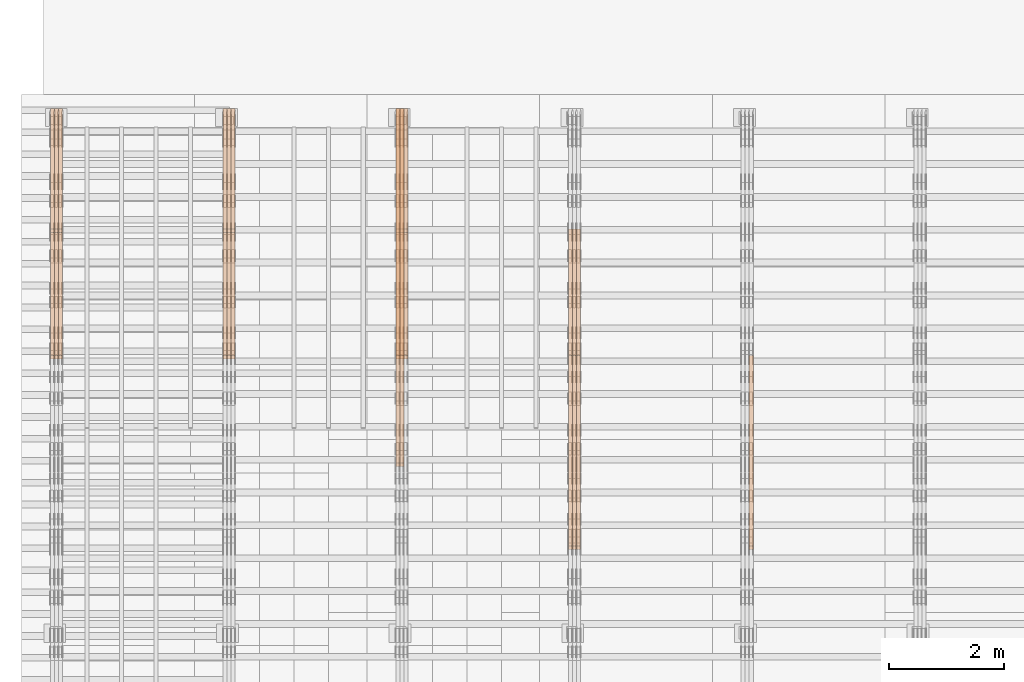
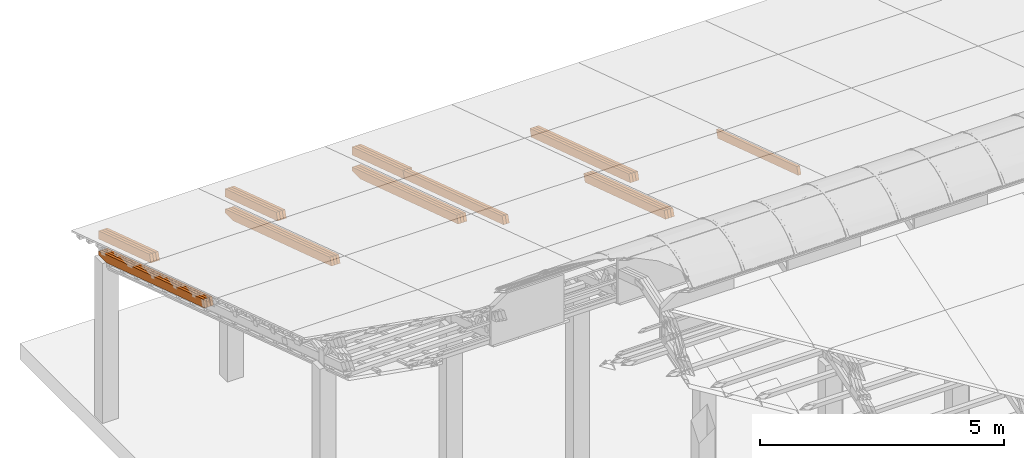
# One storey, part 20 of 385: 27 proxies.
"""IFC2X3 building model written with IfcOpenShell, lengths in millimetres."""

from ifc_helpers import new_model, entity, si_unit, converted_unit, derived_unit, direction, frame, origin, place, context, subcontext, project, spatial, polyline, outline, extrude, source, transform, mapped, material, type_object, type_shapes, element, save


model = new_model("IFC2X3")

# Units and contexts
model_context = context("Model", 3, precision=0.01, world=origin(), true_north=direction((6.12303176911189e-17, 1.0)))
body_context = subcontext(model_context, "Body", "Model", "MODEL_VIEW")
ifc_project = project(units=[si_unit("LENGTHUNIT", "METRE", prefix="MILLI"), si_unit("AREAUNIT", "SQUARE_METRE"), si_unit("VOLUMEUNIT", "CUBIC_METRE"), converted_unit("PLANEANGLEUNIT", "DEGREE", entity("IfcRatioMeasure", 0.0174532925199433), si_unit("PLANEANGLEUNIT", "RADIAN"), dimensions=[0, 0, 0, 0, 0, 0, 0]), si_unit("MASSUNIT", "GRAM", prefix="KILO"), derived_unit("MASSDENSITYUNIT", [(si_unit("MASSUNIT", "GRAM", prefix="KILO"), 1), (si_unit("LENGTHUNIT", "METRE"), -3)]), si_unit("TIMEUNIT", "SECOND"), si_unit("FREQUENCYUNIT", "HERTZ"), si_unit("THERMODYNAMICTEMPERATUREUNIT", "DEGREE_CELSIUS"), derived_unit("THERMALTRANSMITTANCEUNIT", [(si_unit("MASSUNIT", "GRAM", prefix="KILO"), 1), (si_unit("THERMODYNAMICTEMPERATUREUNIT", "KELVIN"), -1), (si_unit("TIMEUNIT", "SECOND"), -3)]), derived_unit("VOLUMETRICFLOWRATEUNIT", [(si_unit("LENGTHUNIT", "METRE"), 3), (si_unit("TIMEUNIT", "SECOND"), -1)]), si_unit("ELECTRICCURRENTUNIT", "AMPERE"), si_unit("ELECTRICVOLTAGEUNIT", "VOLT"), si_unit("POWERUNIT", "WATT"), si_unit("FORCEUNIT", "NEWTON", prefix="KILO"), si_unit("ILLUMINANCEUNIT", "LUX"), si_unit("LUMINOUSFLUXUNIT", "LUMEN"), si_unit("LUMINOUSINTENSITYUNIT", "CANDELA"), derived_unit("USERDEFINED", [(si_unit("MASSUNIT", "GRAM", prefix="KILO"), -1), (si_unit("LENGTHUNIT", "METRE"), -2), (si_unit("TIMEUNIT", "SECOND"), 3), (si_unit("LUMINOUSFLUXUNIT", "LUMEN"), 1)]), derived_unit("LINEARVELOCITYUNIT", [(si_unit("LENGTHUNIT", "METRE"), 1), (si_unit("TIMEUNIT", "SECOND"), -1)]), si_unit("PRESSUREUNIT", "PASCAL"), derived_unit("USERDEFINED", [(si_unit("LENGTHUNIT", "METRE"), -2), (si_unit("MASSUNIT", "GRAM", prefix="KILO"), 1), (si_unit("TIMEUNIT", "SECOND"), -2)])], contexts=[model_context])

# Site, building, storey
site_placement = place(None, origin())
site = spatial("IfcSite", under=ifc_project, at=site_placement, CompositionType="ELEMENT")
building_placement = place(site_placement, origin())
building = spatial("IfcBuilding", under=site, at=building_placement, CompositionType="ELEMENT")
storey_placement = place(building_placement, origin())
storey = spatial("IfcBuildingStorey", under=building, at=storey_placement, Name="Default", CompositionType="ELEMENT", Elevation=0.0)

# Proxies
ifc_material_1 = material(Name="IfcSurfaceStyle #144522")
building_element_proxy_type_1 = type_object("IfcBuildingElementProxyType", Name="T1-B2 144520", PredefinedType="NOTDEFINED", material=ifc_material_1)
shared_shape_1 = source(origin(), body_context, "Body", "SweptSolid", [
    extrude(outline(polyline([(-1738.61933402934, -97.4999466901035), (1738.6190788485, -97.4999466901035), (1738.6191018378, 97.4999466901035), (-1738.61884665697, 97.4999466901035), (-1738.61933402934, -97.4999466901035)])), frame((1738.6191018378, 97.4999528847471, 0.0), z_axis=(0.0, 0.0, 1.0), x_axis=(-1.0, 0.0, 0.0)), (0.0, 0.0, 1.0), 69.9999999999998),
])
type_shapes(building_element_proxy_type_1, [shared_shape_1])
proxy_1_placement = place(building_placement, frame((12385.0, 22140.4521465233, 1306.03026754604), z_axis=(-1.0, 0.0, 0.0), x_axis=(0.0, -0.951056516295124, 0.309016994375039)))
element("IfcBuildingElementProxy", 1, at=proxy_1_placement, inside=storey, type_object=building_element_proxy_type_1, material=ifc_material_1, Name="T1-B2", context=body_context, shape_type="MappedRepresentation", body=[
    mapped(shared_shape_1, transform((0.0, 0.0, 0.0), scale=1.0)),
])
ifc_material_2 = material(Name="IfcSurfaceStyle #111485")
building_element_proxy_type_2 = type_object("IfcBuildingElementProxyType", Name="T1-T2 111483", PredefinedType="NOTDEFINED", material=ifc_material_2)
shared_shape_2 = source(origin(), body_context, "Body", "SweptSolid", [
    extrude(outline(polyline([(-2137.04373183812, -97.5000250291418), (2137.04394104036, -97.5000250291418), (2137.04396402965, 97.5000250291418), (-2137.04417323189, 97.5000250291418), (-2137.04373183812, -97.5000250291418)])), frame((2137.04396402965, 97.5001541485632, 0.0), z_axis=(0.0, 0.0, 1.0), x_axis=(-1.0, 0.0, 0.0)), (0.0, 0.0, 1.0), 69.9999999999997),
])
type_shapes(building_element_proxy_type_2, [shared_shape_2])
proxy_2_placement = place(building_placement, frame((9385.0, 24344.7841397874, 1095.2368156767), z_axis=(-1.0, 0.0, 0.0), x_axis=(0.0, -0.951056516295154, 0.309016994374948)))
element("IfcBuildingElementProxy", 2, at=proxy_2_placement, inside=storey, type_object=building_element_proxy_type_2, material=ifc_material_2, Name="T1-T2", context=body_context, shape_type="MappedRepresentation", body=[
    mapped(shared_shape_2, transform((0.0, 0.0, 0.0), scale=1.0)),
])
ifc_material_3 = material(Name="IfcSurfaceStyle #111428")
building_element_proxy_type_3 = type_object("IfcBuildingElementProxyType", Name="T1-T2 111426", PredefinedType="NOTDEFINED", material=ifc_material_3)
shared_shape_3 = source(origin(), body_context, "Body", "SweptSolid", [
    extrude(outline(polyline([(-2137.04373183812, -97.5000250291418), (2137.04394104036, -97.5000250291418), (2137.04396402965, 97.5000250291418), (-2137.04417323189, 97.5000250291418), (-2137.04373183812, -97.5000250291418)])), frame((2137.04396402965, 97.5001541485632, 0.0), z_axis=(0.0, 0.0, 1.0), x_axis=(-1.0, 0.0, 0.0)), (0.0, 0.0, 1.0), 69.9999999999997),
])
type_shapes(building_element_proxy_type_3, [shared_shape_3])
proxy_3_placement = place(building_placement, frame((9315.0, 24344.7841397874, 1095.2368156767), z_axis=(-1.0, 0.0, 0.0), x_axis=(0.0, -0.951056516295154, 0.309016994374948)))
element("IfcBuildingElementProxy", 3, at=proxy_3_placement, inside=storey, type_object=building_element_proxy_type_3, material=ifc_material_3, Name="T1-T2", context=body_context, shape_type="MappedRepresentation", body=[
    mapped(shared_shape_3, transform((0.0, 0.0, 0.0), scale=1.0)),
])
ifc_material_4 = material(Name="IfcSurfaceStyle #111371")
building_element_proxy_type_4 = type_object("IfcBuildingElementProxyType", Name="T1-T2 111369", PredefinedType="NOTDEFINED", material=ifc_material_4)
shared_shape_4 = source(origin(), body_context, "Body", "SweptSolid", [
    extrude(outline(polyline([(-2137.04373183812, -97.5000250291418), (2137.04394104036, -97.5000250291418), (2137.04396402965, 97.5000250291418), (-2137.04417323189, 97.5000250291418), (-2137.04373183812, -97.5000250291418)])), frame((2137.04396402965, 97.5001541485632, 0.0), z_axis=(0.0, 0.0, 1.0), x_axis=(-1.0, 0.0, 0.0)), (0.0, 0.0, 1.0), 69.9999999999997),
])
type_shapes(building_element_proxy_type_4, [shared_shape_4])
proxy_4_placement = place(building_placement, frame((9245.0, 24344.7841397874, 1095.2368156767), z_axis=(-1.0, 0.0, 0.0), x_axis=(0.0, -0.951056516295154, 0.309016994374948)))
element("IfcBuildingElementProxy", 4, at=proxy_4_placement, inside=storey, type_object=building_element_proxy_type_4, material=ifc_material_4, Name="T1-T2", context=body_context, shape_type="MappedRepresentation", body=[
    mapped(shared_shape_4, transform((0.0, 0.0, 0.0), scale=1.0)),
])
ifc_material_5 = material(Name="IfcSurfaceStyle #110090")
building_element_proxy_type_5 = type_object("IfcBuildingElementProxyType", Name="T1-B2 110088", PredefinedType="NOTDEFINED", material=ifc_material_5)
shared_shape_5 = source(origin(), body_context, "Body", "SweptSolid", [
    extrude(outline(polyline([(-1738.61933402934, -97.4999466901035), (1738.6190788485, -97.4999466901035), (1738.6191018378, 97.4999466901035), (-1738.61884665697, 97.4999466901035), (-1738.61933402934, -97.4999466901035)])), frame((1738.6191018378, 97.4999528847471, 0.0), z_axis=(0.0, 0.0, 1.0), x_axis=(-1.0, 0.0, 0.0)), (0.0, 0.0, 1.0), 69.9999999999998),
])
type_shapes(building_element_proxy_type_5, [shared_shape_5])
proxy_5_placement = place(building_placement, frame((9385.0, 22140.4521465233, 1306.03026754604), z_axis=(-1.0, 0.0, 0.0), x_axis=(0.0, -0.951056516295124, 0.309016994375039)))
element("IfcBuildingElementProxy", 5, at=proxy_5_placement, inside=storey, type_object=building_element_proxy_type_5, material=ifc_material_5, Name="T1-B2", context=body_context, shape_type="MappedRepresentation", body=[
    mapped(shared_shape_5, transform((0.0, 0.0, 0.0), scale=1.0)),
])
ifc_material_6 = material(Name="IfcSurfaceStyle #110033")
building_element_proxy_type_6 = type_object("IfcBuildingElementProxyType", Name="T1-B2 110031", PredefinedType="NOTDEFINED", material=ifc_material_6)
shared_shape_6 = source(origin(), body_context, "Body", "SweptSolid", [
    extrude(outline(polyline([(-1738.61933402934, -97.4999466901035), (1738.6190788485, -97.4999466901035), (1738.6191018378, 97.4999466901035), (-1738.61884665697, 97.4999466901035), (-1738.61933402934, -97.4999466901035)])), frame((1738.6191018378, 97.4999528847471, 0.0), z_axis=(0.0, 0.0, 1.0), x_axis=(-1.0, 0.0, 0.0)), (0.0, 0.0, 1.0), 69.9999999999998),
])
type_shapes(building_element_proxy_type_6, [shared_shape_6])
proxy_6_placement = place(building_placement, frame((9315.0, 22140.4521465233, 1306.03026754604), z_axis=(-1.0, 0.0, 0.0), x_axis=(0.0, -0.951056516295124, 0.309016994375039)))
element("IfcBuildingElementProxy", 6, at=proxy_6_placement, inside=storey, type_object=building_element_proxy_type_6, material=ifc_material_6, Name="T1-B2", context=body_context, shape_type="MappedRepresentation", body=[
    mapped(shared_shape_6, transform((0.0, 0.0, 0.0), scale=1.0)),
])
ifc_material_7 = material(Name="IfcSurfaceStyle #109976")
building_element_proxy_type_7 = type_object("IfcBuildingElementProxyType", Name="T1-B2 109974", PredefinedType="NOTDEFINED", material=ifc_material_7)
shared_shape_7 = source(origin(), body_context, "Body", "SweptSolid", [
    extrude(outline(polyline([(-1738.61933402934, -97.4999466901035), (1738.6190788485, -97.4999466901035), (1738.6191018378, 97.4999466901035), (-1738.61884665697, 97.4999466901035), (-1738.61933402934, -97.4999466901035)])), frame((1738.6191018378, 97.4999528847471, 0.0), z_axis=(0.0, 0.0, 1.0), x_axis=(-1.0, 0.0, 0.0)), (0.0, 0.0, 1.0), 69.9999999999998),
])
type_shapes(building_element_proxy_type_7, [shared_shape_7])
proxy_7_placement = place(building_placement, frame((9245.0, 22140.4521465233, 1306.03026754604), z_axis=(-1.0, 0.0, 0.0), x_axis=(0.0, -0.951056516295124, 0.309016994375039)))
element("IfcBuildingElementProxy", 7, at=proxy_7_placement, inside=storey, type_object=building_element_proxy_type_7, material=ifc_material_7, Name="T1-B2", context=body_context, shape_type="MappedRepresentation", body=[
    mapped(shared_shape_7, transform((0.0, 0.0, 0.0), scale=1.0)),
])
ifc_material_8 = material(Name="IfcSurfaceStyle #76996")
building_element_proxy_type_8 = type_object("IfcBuildingElementProxyType", Name="T1-T2 76994", PredefinedType="NOTDEFINED", material=ifc_material_8)
shared_shape_8 = source(origin(), body_context, "Body", "SweptSolid", [
    extrude(outline(polyline([(-2137.04373183812, -97.5000250291418), (2137.04394104036, -97.5000250291418), (2137.04396402965, 97.5000250291418), (-2137.04417323189, 97.5000250291418), (-2137.04373183812, -97.5000250291418)])), frame((2137.04396402965, 97.5001541485632, 0.0), z_axis=(0.0, 0.0, 1.0), x_axis=(-1.0, 0.0, 0.0)), (0.0, 0.0, 1.0), 69.9999999999997),
])
type_shapes(building_element_proxy_type_8, [shared_shape_8])
proxy_8_placement = place(building_placement, frame((6315.0, 24344.7841397874, 1095.2368156767), z_axis=(-1.0, 0.0, 0.0), x_axis=(0.0, -0.951056516295154, 0.309016994374948)))
element("IfcBuildingElementProxy", 8, at=proxy_8_placement, inside=storey, type_object=building_element_proxy_type_8, material=ifc_material_8, Name="T1-T2", context=body_context, shape_type="MappedRepresentation", body=[
    mapped(shared_shape_8, transform((0.0, 0.0, 0.0), scale=1.0)),
])
ifc_material_9 = material(Name="IfcSurfaceStyle #76939")
building_element_proxy_type_9 = type_object("IfcBuildingElementProxyType", Name="T1-T2 76937", PredefinedType="NOTDEFINED", material=ifc_material_9)
shared_shape_9 = source(origin(), body_context, "Body", "SweptSolid", [
    extrude(outline(polyline([(-2137.04373183812, -97.5000250291418), (2137.04394104036, -97.5000250291418), (2137.04396402965, 97.5000250291418), (-2137.04417323189, 97.5000250291418), (-2137.04373183812, -97.5000250291418)])), frame((2137.04396402965, 97.5001541485632, 0.0), z_axis=(0.0, 0.0, 1.0), x_axis=(-1.0, 0.0, 0.0)), (0.0, 0.0, 1.0), 69.9999999999997),
])
type_shapes(building_element_proxy_type_9, [shared_shape_9])
proxy_9_placement = place(building_placement, frame((6245.0, 24344.7841397874, 1095.2368156767), z_axis=(-1.0, 0.0, 0.0), x_axis=(0.0, -0.951056516295154, 0.309016994374948)))
element("IfcBuildingElementProxy", 9, at=proxy_9_placement, inside=storey, type_object=building_element_proxy_type_9, material=ifc_material_9, Name="T1-T2", context=body_context, shape_type="MappedRepresentation", body=[
    mapped(shared_shape_9, transform((0.0, 0.0, 0.0), scale=1.0)),
])
ifc_material_10 = material(Name="IfcSurfaceStyle #76882")
building_element_proxy_type_10 = type_object("IfcBuildingElementProxyType", Name="T1-T3 76880", PredefinedType="NOTDEFINED", material=ifc_material_10)
shared_shape_10 = source(origin(), body_context, "Body", "SweptSolid", [
    extrude(outline(polyline([(-1117.22419189679, -97.5000115568039), (1085.54451125458, -97.5000115568039), (1148.90384954971, 97.5000115568039), (-1117.2241689075, 97.5000115568039), (-1117.22419189679, -97.5000115568039)])), frame((1148.90385201956, 97.5000191595882, 0.0), z_axis=(0.0, 0.0, 1.0), x_axis=(-1.0, 0.0, 0.0)), (0.0, 0.0, 1.0), 69.9999999999999),
])
type_shapes(building_element_proxy_type_10, [shared_shape_10])
proxy_10_placement = place(building_placement, frame((6385.0, 26500.0, 394.964866273674), z_axis=(-1.0, 0.0, 0.0), x_axis=(0.0, -0.951056516295154, 0.309016994374948)))
element("IfcBuildingElementProxy", 10, at=proxy_10_placement, inside=storey, type_object=building_element_proxy_type_10, material=ifc_material_10, Name="T1-T3", context=body_context, shape_type="MappedRepresentation", body=[
    mapped(shared_shape_10, transform((0.0, 0.0, 0.0), scale=1.0)),
])
ifc_material_11 = material(Name="IfcSurfaceStyle #76825")
building_element_proxy_type_11 = type_object("IfcBuildingElementProxyType", Name="T1-T3 76823", PredefinedType="NOTDEFINED", material=ifc_material_11)
shared_shape_11 = source(origin(), body_context, "Body", "SweptSolid", [
    extrude(outline(polyline([(-1117.22419189679, -97.5000115568039), (1085.54451125458, -97.5000115568039), (1148.90384954971, 97.5000115568039), (-1117.2241689075, 97.5000115568039), (-1117.22419189679, -97.5000115568039)])), frame((1148.90385201956, 97.5000191595882, 0.0), z_axis=(0.0, 0.0, 1.0), x_axis=(-1.0, 0.0, 0.0)), (0.0, 0.0, 1.0), 69.9999999999999),
])
type_shapes(building_element_proxy_type_11, [shared_shape_11])
proxy_11_placement = place(building_placement, frame((6315.0, 26500.0, 394.964866273674), z_axis=(-1.0, 0.0, 0.0), x_axis=(0.0, -0.951056516295154, 0.309016994374948)))
element("IfcBuildingElementProxy", 11, at=proxy_11_placement, inside=storey, type_object=building_element_proxy_type_11, material=ifc_material_11, Name="T1-T3", context=body_context, shape_type="MappedRepresentation", body=[
    mapped(shared_shape_11, transform((0.0, 0.0, 0.0), scale=1.0)),
])
ifc_material_12 = material(Name="IfcSurfaceStyle #76768")
building_element_proxy_type_12 = type_object("IfcBuildingElementProxyType", Name="T1-T3 76766", PredefinedType="NOTDEFINED", material=ifc_material_12)
shared_shape_12 = source(origin(), body_context, "Body", "SweptSolid", [
    extrude(outline(polyline([(-1117.22419189679, -97.5000115568039), (1085.54451125458, -97.5000115568039), (1148.90384954971, 97.5000115568039), (-1117.2241689075, 97.5000115568039), (-1117.22419189679, -97.5000115568039)])), frame((1148.90385201956, 97.5000191595882, 0.0), z_axis=(0.0, 0.0, 1.0), x_axis=(-1.0, 0.0, 0.0)), (0.0, 0.0, 1.0), 69.9999999999999),
])
type_shapes(building_element_proxy_type_12, [shared_shape_12])
proxy_12_placement = place(building_placement, frame((6245.0, 26500.0, 394.964866273674), z_axis=(-1.0, 0.0, 0.0), x_axis=(0.0, -0.951056516295154, 0.309016994374948)))
element("IfcBuildingElementProxy", 12, at=proxy_12_placement, inside=storey, type_object=building_element_proxy_type_12, material=ifc_material_12, Name="T1-T3", context=body_context, shape_type="MappedRepresentation", body=[
    mapped(shared_shape_12, transform((0.0, 0.0, 0.0), scale=1.0)),
])
ifc_material_13 = material(Name="IfcSurfaceStyle #75487")
building_element_proxy_type_13 = type_object("IfcBuildingElementProxyType", Name="T1-B1 75485", PredefinedType="NOTDEFINED", material=ifc_material_13)
shared_shape_13 = source(origin(), body_context, "Body", "SweptSolid", [
    extrude(outline(polyline([(-2659.34106034305, -95.9868650736445), (1861.19950396595, -95.9868650736445), (1890.42090463564, -6.05260867570997), (1567.0616890952, 99.0131694114995), (-2659.34103735375, 99.0131694114995), (-2659.34106034305, -95.9868650736445)])), frame((1890.42090463564, 99.013169411504, 0.0), z_axis=(0.0, 0.0, 1.0), x_axis=(-1.0, 0.0, 0.0)), (0.0, 0.0, 1.0), 69.9999999999997),
])
type_shapes(building_element_proxy_type_13, [shared_shape_13])
proxy_13_placement = place(building_placement, frame((6385.0, 26467.5328890438, -99.9234928894624), z_axis=(-1.0, 0.0, 0.0), x_axis=(0.0, -0.951056516295124, 0.309016994375039)))
element("IfcBuildingElementProxy", 13, at=proxy_13_placement, inside=storey, type_object=building_element_proxy_type_13, material=ifc_material_13, Name="T1-B1", context=body_context, shape_type="MappedRepresentation", body=[
    mapped(shared_shape_13, transform((0.0, 0.0, 0.0), scale=1.0)),
])
ifc_material_14 = material(Name="IfcSurfaceStyle #75421")
building_element_proxy_type_14 = type_object("IfcBuildingElementProxyType", Name="T1-B1 75419", PredefinedType="NOTDEFINED", material=ifc_material_14)
shared_shape_14 = source(origin(), body_context, "Body", "SweptSolid", [
    extrude(outline(polyline([(-2659.34106034305, -95.9868650736445), (1861.19950396595, -95.9868650736445), (1890.42090463564, -6.05260867570997), (1567.0616890952, 99.0131694114995), (-2659.34103735375, 99.0131694114995), (-2659.34106034305, -95.9868650736445)])), frame((1890.42090463564, 99.013169411504, 0.0), z_axis=(0.0, 0.0, 1.0), x_axis=(-1.0, 0.0, 0.0)), (0.0, 0.0, 1.0), 69.9999999999997),
])
type_shapes(building_element_proxy_type_14, [shared_shape_14])
proxy_14_placement = place(building_placement, frame((6315.0, 26467.5328890438, -99.9234928894624), z_axis=(-1.0, 0.0, 0.0), x_axis=(0.0, -0.951056516295124, 0.309016994375039)))
element("IfcBuildingElementProxy", 14, at=proxy_14_placement, inside=storey, type_object=building_element_proxy_type_14, material=ifc_material_14, Name="T1-B1", context=body_context, shape_type="MappedRepresentation", body=[
    mapped(shared_shape_14, transform((0.0, 0.0, 0.0), scale=1.0)),
])
ifc_material_15 = material(Name="IfcSurfaceStyle #75355")
building_element_proxy_type_15 = type_object("IfcBuildingElementProxyType", Name="T1-B1 75353", PredefinedType="NOTDEFINED", material=ifc_material_15)
shared_shape_15 = source(origin(), body_context, "Body", "SweptSolid", [
    extrude(outline(polyline([(-2659.34106034305, -95.9868650736445), (1861.19950396595, -95.9868650736445), (1890.42090463564, -6.05260867570997), (1567.0616890952, 99.0131694114995), (-2659.34103735375, 99.0131694114995), (-2659.34106034305, -95.9868650736445)])), frame((1890.42090463564, 99.013169411504, 0.0), z_axis=(0.0, 0.0, 1.0), x_axis=(-1.0, 0.0, 0.0)), (0.0, 0.0, 1.0), 69.9999999999997),
])
type_shapes(building_element_proxy_type_15, [shared_shape_15])
proxy_15_placement = place(building_placement, frame((6245.0, 26467.5328890438, -99.9234928894624), z_axis=(-1.0, 0.0, 0.0), x_axis=(0.0, -0.951056516295124, 0.309016994375039)))
element("IfcBuildingElementProxy", 15, at=proxy_15_placement, inside=storey, type_object=building_element_proxy_type_15, material=ifc_material_15, Name="T1-B1", context=body_context, shape_type="MappedRepresentation", body=[
    mapped(shared_shape_15, transform((0.0, 0.0, 0.0), scale=1.0)),
])
ifc_material_16 = material(Name="IfcSurfaceStyle #42450")
building_element_proxy_type_16 = type_object("IfcBuildingElementProxyType", Name="T1-T3 42448", PredefinedType="NOTDEFINED", material=ifc_material_16)
shared_shape_16 = source(origin(), body_context, "Body", "SweptSolid", [
    extrude(outline(polyline([(-1117.22419189679, -97.5000115568039), (1085.54451125458, -97.5000115568039), (1148.90384954971, 97.5000115568039), (-1117.2241689075, 97.5000115568039), (-1117.22419189679, -97.5000115568039)])), frame((1148.90385201956, 97.5000191595882, 0.0), z_axis=(0.0, 0.0, 1.0), x_axis=(-1.0, 0.0, 0.0)), (0.0, 0.0, 1.0), 69.9999999999999),
])
type_shapes(building_element_proxy_type_16, [shared_shape_16])
proxy_16_placement = place(building_placement, frame((3385.0, 26500.0, 394.964866273674), z_axis=(-1.0, 0.0, 0.0), x_axis=(0.0, -0.951056516295154, 0.309016994374948)))
element("IfcBuildingElementProxy", 16, at=proxy_16_placement, inside=storey, type_object=building_element_proxy_type_16, material=ifc_material_16, Name="T1-T3", context=body_context, shape_type="MappedRepresentation", body=[
    mapped(shared_shape_16, transform((0.0, 0.0, 0.0), scale=1.0)),
])
ifc_material_17 = material(Name="IfcSurfaceStyle #42393")
building_element_proxy_type_17 = type_object("IfcBuildingElementProxyType", Name="T1-T3 42391", PredefinedType="NOTDEFINED", material=ifc_material_17)
shared_shape_17 = source(origin(), body_context, "Body", "SweptSolid", [
    extrude(outline(polyline([(-1117.22419189679, -97.5000115568039), (1085.54451125458, -97.5000115568039), (1148.90384954971, 97.5000115568039), (-1117.2241689075, 97.5000115568039), (-1117.22419189679, -97.5000115568039)])), frame((1148.90385201956, 97.5000191595882, 0.0), z_axis=(0.0, 0.0, 1.0), x_axis=(-1.0, 0.0, 0.0)), (0.0, 0.0, 1.0), 69.9999999999999),
])
type_shapes(building_element_proxy_type_17, [shared_shape_17])
proxy_17_placement = place(building_placement, frame((3315.0, 26500.0, 394.964866273674), z_axis=(-1.0, 0.0, 0.0), x_axis=(0.0, -0.951056516295154, 0.309016994374948)))
element("IfcBuildingElementProxy", 17, at=proxy_17_placement, inside=storey, type_object=building_element_proxy_type_17, material=ifc_material_17, Name="T1-T3", context=body_context, shape_type="MappedRepresentation", body=[
    mapped(shared_shape_17, transform((0.0, 0.0, 0.0), scale=1.0)),
])
ifc_material_18 = material(Name="IfcSurfaceStyle #42336")
building_element_proxy_type_18 = type_object("IfcBuildingElementProxyType", Name="T1-T3 42334", PredefinedType="NOTDEFINED", material=ifc_material_18)
shared_shape_18 = source(origin(), body_context, "Body", "SweptSolid", [
    extrude(outline(polyline([(-1117.22419189679, -97.5000115568039), (1085.54451125458, -97.5000115568039), (1148.90384954971, 97.5000115568039), (-1117.2241689075, 97.5000115568039), (-1117.22419189679, -97.5000115568039)])), frame((1148.90385201956, 97.5000191595882, 0.0), z_axis=(0.0, 0.0, 1.0), x_axis=(-1.0, 0.0, 0.0)), (0.0, 0.0, 1.0), 69.9999999999999),
])
type_shapes(building_element_proxy_type_18, [shared_shape_18])
proxy_18_placement = place(building_placement, frame((3245.0, 26500.0, 394.964866273674), z_axis=(-1.0, 0.0, 0.0), x_axis=(0.0, -0.951056516295154, 0.309016994374948)))
element("IfcBuildingElementProxy", 18, at=proxy_18_placement, inside=storey, type_object=building_element_proxy_type_18, material=ifc_material_18, Name="T1-T3", context=body_context, shape_type="MappedRepresentation", body=[
    mapped(shared_shape_18, transform((0.0, 0.0, 0.0), scale=1.0)),
])
ifc_material_19 = material(Name="IfcSurfaceStyle #41055")
building_element_proxy_type_19 = type_object("IfcBuildingElementProxyType", Name="T1-B1 41053", PredefinedType="NOTDEFINED", material=ifc_material_19)
shared_shape_19 = source(origin(), body_context, "Body", "SweptSolid", [
    extrude(outline(polyline([(-2659.34106034305, -95.9868650736445), (1861.19950396595, -95.9868650736445), (1890.42090463564, -6.05260867570997), (1567.0616890952, 99.0131694114995), (-2659.34103735375, 99.0131694114995), (-2659.34106034305, -95.9868650736445)])), frame((1890.42090463564, 99.013169411504, 0.0), z_axis=(0.0, 0.0, 1.0), x_axis=(-1.0, 0.0, 0.0)), (0.0, 0.0, 1.0), 69.9999999999997),
])
type_shapes(building_element_proxy_type_19, [shared_shape_19])
proxy_19_placement = place(building_placement, frame((3385.0, 26467.5328890438, -99.9234928894624), z_axis=(-1.0, 0.0, 0.0), x_axis=(0.0, -0.951056516295124, 0.309016994375039)))
element("IfcBuildingElementProxy", 19, at=proxy_19_placement, inside=storey, type_object=building_element_proxy_type_19, material=ifc_material_19, Name="T1-B1", context=body_context, shape_type="MappedRepresentation", body=[
    mapped(shared_shape_19, transform((0.0, 0.0, 0.0), scale=1.0)),
])
ifc_material_20 = material(Name="IfcSurfaceStyle #40989")
building_element_proxy_type_20 = type_object("IfcBuildingElementProxyType", Name="T1-B1 40987", PredefinedType="NOTDEFINED", material=ifc_material_20)
shared_shape_20 = source(origin(), body_context, "Body", "SweptSolid", [
    extrude(outline(polyline([(-2659.34106034305, -95.9868650736445), (1861.19950396595, -95.9868650736445), (1890.42090463564, -6.05260867570997), (1567.0616890952, 99.0131694114995), (-2659.34103735375, 99.0131694114995), (-2659.34106034305, -95.9868650736445)])), frame((1890.42090463564, 99.013169411504, 0.0), z_axis=(0.0, 0.0, 1.0), x_axis=(-1.0, 0.0, 0.0)), (0.0, 0.0, 1.0), 69.9999999999997),
])
type_shapes(building_element_proxy_type_20, [shared_shape_20])
proxy_20_placement = place(building_placement, frame((3315.0, 26467.5328890438, -99.9234928894624), z_axis=(-1.0, 0.0, 0.0), x_axis=(0.0, -0.951056516295124, 0.309016994375039)))
element("IfcBuildingElementProxy", 20, at=proxy_20_placement, inside=storey, type_object=building_element_proxy_type_20, material=ifc_material_20, Name="T1-B1", context=body_context, shape_type="MappedRepresentation", body=[
    mapped(shared_shape_20, transform((0.0, 0.0, 0.0), scale=1.0)),
])
ifc_material_21 = material(Name="IfcSurfaceStyle #40923")
building_element_proxy_type_21 = type_object("IfcBuildingElementProxyType", Name="T1-B1 40921", PredefinedType="NOTDEFINED", material=ifc_material_21)
shared_shape_21 = source(origin(), body_context, "Body", "SweptSolid", [
    extrude(outline(polyline([(-2659.34106034305, -95.9868650736445), (1861.19950396595, -95.9868650736445), (1890.42090463564, -6.05260867570997), (1567.0616890952, 99.0131694114995), (-2659.34103735375, 99.0131694114995), (-2659.34106034305, -95.9868650736445)])), frame((1890.42090463564, 99.013169411504, 0.0), z_axis=(0.0, 0.0, 1.0), x_axis=(-1.0, 0.0, 0.0)), (0.0, 0.0, 1.0), 69.9999999999997),
])
type_shapes(building_element_proxy_type_21, [shared_shape_21])
proxy_21_placement = place(building_placement, frame((3245.0, 26467.5328890438, -99.9234928894624), z_axis=(-1.0, 0.0, 0.0), x_axis=(0.0, -0.951056516295124, 0.309016994375039)))
element("IfcBuildingElementProxy", 21, at=proxy_21_placement, inside=storey, type_object=building_element_proxy_type_21, material=ifc_material_21, Name="T1-B1", context=body_context, shape_type="MappedRepresentation", body=[
    mapped(shared_shape_21, transform((0.0, 0.0, 0.0), scale=1.0)),
])
ifc_material_22 = material(Name="IfcSurfaceStyle #8018")
building_element_proxy_type_22 = type_object("IfcBuildingElementProxyType", Name="T1-T3 8016", PredefinedType="NOTDEFINED", material=ifc_material_22)
shared_shape_22 = source(origin(), body_context, "Body", "SweptSolid", [
    extrude(outline(polyline([(-1117.22419189679, -97.5000115568039), (1085.54451125458, -97.5000115568039), (1148.90384954971, 97.5000115568039), (-1117.2241689075, 97.5000115568039), (-1117.22419189679, -97.5000115568039)])), frame((1148.90385201956, 97.5000191595882, 0.0), z_axis=(0.0, 0.0, 1.0), x_axis=(-1.0, 0.0, 0.0)), (0.0, 0.0, 1.0), 69.9999999999999),
])
type_shapes(building_element_proxy_type_22, [shared_shape_22])
proxy_22_placement = place(building_placement, frame((385.0, 26500.0, 394.964866273674), z_axis=(-1.0, 0.0, 0.0), x_axis=(0.0, -0.951056516295154, 0.309016994374948)))
element("IfcBuildingElementProxy", 22, at=proxy_22_placement, inside=storey, type_object=building_element_proxy_type_22, material=ifc_material_22, Name="T1-T3", context=body_context, shape_type="MappedRepresentation", body=[
    mapped(shared_shape_22, transform((0.0, 0.0, 0.0), scale=1.0)),
])
ifc_material_23 = material(Name="IfcSurfaceStyle #7961")
building_element_proxy_type_23 = type_object("IfcBuildingElementProxyType", Name="T1-T3 7959", PredefinedType="NOTDEFINED", material=ifc_material_23)
shared_shape_23 = source(origin(), body_context, "Body", "SweptSolid", [
    extrude(outline(polyline([(-1117.22419189679, -97.5000115568039), (1085.54451125458, -97.5000115568039), (1148.90384954971, 97.5000115568039), (-1117.2241689075, 97.5000115568039), (-1117.22419189679, -97.5000115568039)])), frame((1148.90385201956, 97.5000191595882, 0.0), z_axis=(0.0, 0.0, 1.0), x_axis=(-1.0, 0.0, 0.0)), (0.0, 0.0, 1.0), 69.9999999999999),
])
type_shapes(building_element_proxy_type_23, [shared_shape_23])
proxy_23_placement = place(building_placement, frame((315.0, 26500.0, 394.964866273674), z_axis=(-1.0, 0.0, 0.0), x_axis=(0.0, -0.951056516295154, 0.309016994374948)))
element("IfcBuildingElementProxy", 23, at=proxy_23_placement, inside=storey, type_object=building_element_proxy_type_23, material=ifc_material_23, Name="T1-T3", context=body_context, shape_type="MappedRepresentation", body=[
    mapped(shared_shape_23, transform((0.0, 0.0, 0.0), scale=1.0)),
])
ifc_material_24 = material(Name="IfcSurfaceStyle #7904")
building_element_proxy_type_24 = type_object("IfcBuildingElementProxyType", Name="T1-T3 7902", PredefinedType="NOTDEFINED", material=ifc_material_24)
shared_shape_24 = source(origin(), body_context, "Body", "SweptSolid", [
    extrude(outline(polyline([(-1117.22419189679, -97.5000115568039), (1085.54451125458, -97.5000115568039), (1148.90384954971, 97.5000115568039), (-1117.2241689075, 97.5000115568039), (-1117.22419189679, -97.5000115568039)])), frame((1148.90385201956, 97.5000191595882, 0.0), z_axis=(0.0, 0.0, 1.0), x_axis=(-1.0, 0.0, 0.0)), (0.0, 0.0, 1.0), 69.9999999999999),
])
type_shapes(building_element_proxy_type_24, [shared_shape_24])
proxy_24_placement = place(building_placement, frame((245.0, 26500.0, 394.964866273674), z_axis=(-1.0, 0.0, 0.0), x_axis=(0.0, -0.951056516295154, 0.309016994374948)))
element("IfcBuildingElementProxy", 24, at=proxy_24_placement, inside=storey, type_object=building_element_proxy_type_24, material=ifc_material_24, Name="T1-T3", context=body_context, shape_type="MappedRepresentation", body=[
    mapped(shared_shape_24, transform((0.0, 0.0, 0.0), scale=1.0)),
])
ifc_material_25 = material(Name="IfcSurfaceStyle #6623")
building_element_proxy_type_25 = type_object("IfcBuildingElementProxyType", Name="T1-B1 6621", PredefinedType="NOTDEFINED", material=ifc_material_25)
shared_shape_25 = source(origin(), body_context, "Body", "SweptSolid", [
    extrude(outline(polyline([(-2659.34106034305, -95.9868650736445), (1861.19950396595, -95.9868650736445), (1890.42090463564, -6.05260867570997), (1567.0616890952, 99.0131694114995), (-2659.34103735375, 99.0131694114995), (-2659.34106034305, -95.9868650736445)])), frame((1890.42090463564, 99.013169411504, 0.0), z_axis=(0.0, 0.0, 1.0), x_axis=(-1.0, 0.0, 0.0)), (0.0, 0.0, 1.0), 69.9999999999997),
])
type_shapes(building_element_proxy_type_25, [shared_shape_25])
proxy_25_placement = place(building_placement, frame((385.0, 26467.5328890438, -99.9234928894624), z_axis=(-1.0, 0.0, 0.0), x_axis=(0.0, -0.951056516295124, 0.309016994375039)))
element("IfcBuildingElementProxy", 25, at=proxy_25_placement, inside=storey, type_object=building_element_proxy_type_25, material=ifc_material_25, Name="T1-B1", context=body_context, shape_type="MappedRepresentation", body=[
    mapped(shared_shape_25, transform((0.0, 0.0, 0.0), scale=1.0)),
])
ifc_material_26 = material(Name="IfcSurfaceStyle #6557")
building_element_proxy_type_26 = type_object("IfcBuildingElementProxyType", Name="T1-B1 6555", PredefinedType="NOTDEFINED", material=ifc_material_26)
shared_shape_26 = source(origin(), body_context, "Body", "SweptSolid", [
    extrude(outline(polyline([(-2659.34106034305, -95.9868650736445), (1861.19950396595, -95.9868650736445), (1890.42090463564, -6.05260867570997), (1567.0616890952, 99.0131694114995), (-2659.34103735375, 99.0131694114995), (-2659.34106034305, -95.9868650736445)])), frame((1890.42090463564, 99.013169411504, 0.0), z_axis=(0.0, 0.0, 1.0), x_axis=(-1.0, 0.0, 0.0)), (0.0, 0.0, 1.0), 69.9999999999997),
])
type_shapes(building_element_proxy_type_26, [shared_shape_26])
proxy_26_placement = place(building_placement, frame((315.0, 26467.5328890438, -99.9234928894624), z_axis=(-1.0, 0.0, 0.0), x_axis=(0.0, -0.951056516295124, 0.309016994375039)))
element("IfcBuildingElementProxy", 26, at=proxy_26_placement, inside=storey, type_object=building_element_proxy_type_26, material=ifc_material_26, Name="T1-B1", context=body_context, shape_type="MappedRepresentation", body=[
    mapped(shared_shape_26, transform((0.0, 0.0, 0.0), scale=1.0)),
])
ifc_material_27 = material(Name="IfcSurfaceStyle #6491")
building_element_proxy_type_27 = type_object("IfcBuildingElementProxyType", Name="T1-B1 6489", PredefinedType="NOTDEFINED", material=ifc_material_27)
shared_shape_27 = source(origin(), body_context, "Body", "SweptSolid", [
    extrude(outline(polyline([(-2659.34106034305, -95.9868650736445), (1861.19950396595, -95.9868650736445), (1890.42090463564, -6.05260867570997), (1567.0616890952, 99.0131694114995), (-2659.34103735375, 99.0131694114995), (-2659.34106034305, -95.9868650736445)])), frame((1890.42090463564, 99.013169411504, 0.0), z_axis=(0.0, 0.0, 1.0), x_axis=(-1.0, 0.0, 0.0)), (0.0, 0.0, 1.0), 69.9999999999997),
])
type_shapes(building_element_proxy_type_27, [shared_shape_27])
proxy_27_placement = place(building_placement, frame((245.0, 26467.5328890438, -99.9234928894624), z_axis=(-1.0, 0.0, 0.0), x_axis=(0.0, -0.951056516295124, 0.309016994375039)))
element("IfcBuildingElementProxy", 27, at=proxy_27_placement, inside=storey, type_object=building_element_proxy_type_27, material=ifc_material_27, Name="T1-B1", context=body_context, shape_type="MappedRepresentation", body=[
    mapped(shared_shape_27, transform((0.0, 0.0, 0.0), scale=1.0)),
])

save(model, "model.ifc")
